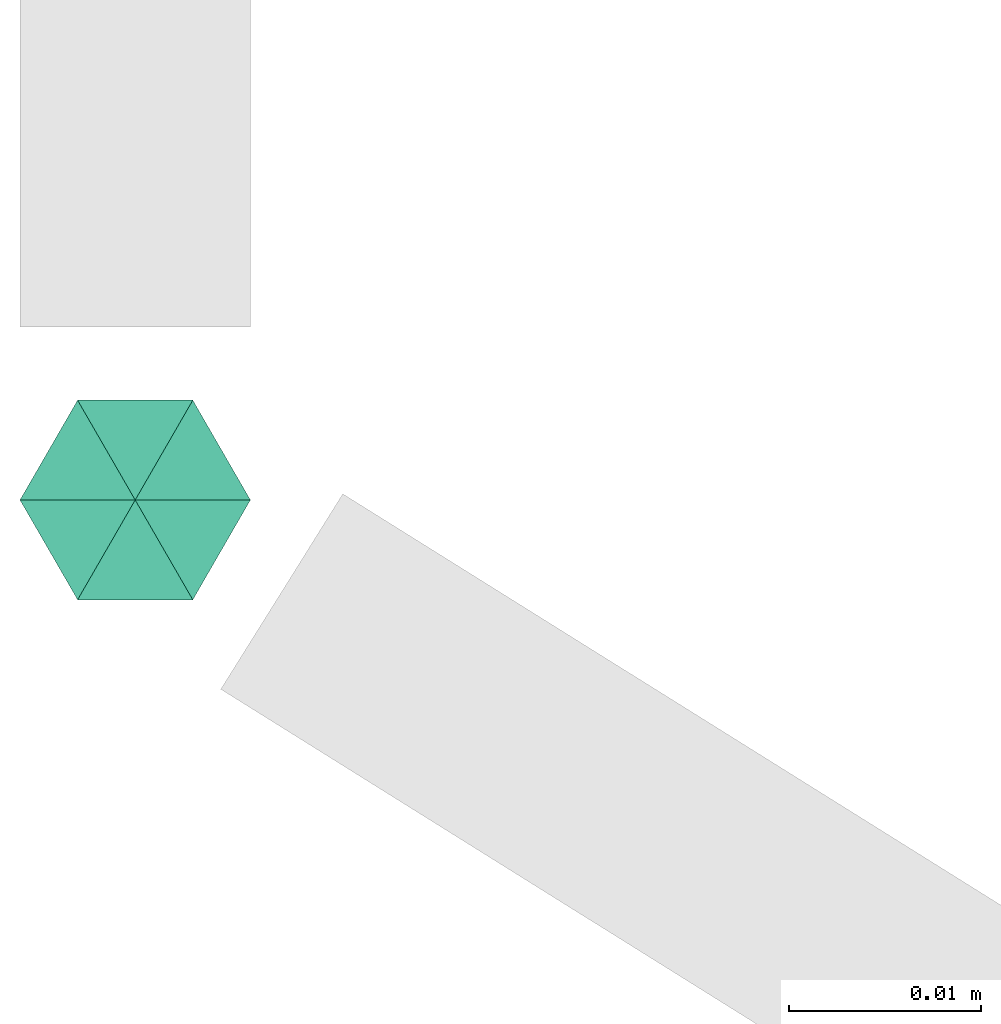
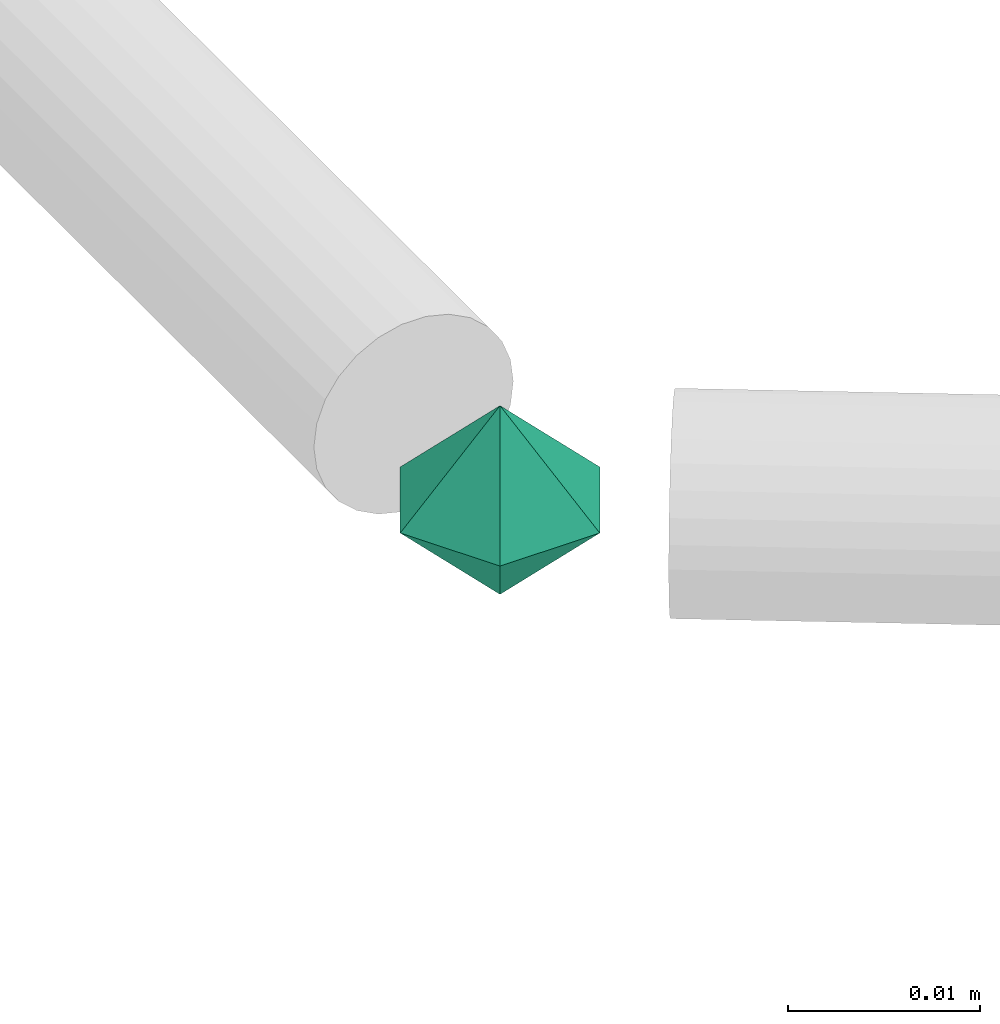
# One storey, part 64 of 65: 1 flow fitting.
"""IFC2X3 building model written with IfcOpenShell, lengths in millimetres."""

from ifc_helpers import new_model, entity, si_unit, converted_unit, derived_unit, direction, frame, origin, place, context, subcontext, project, spatial, faceted_brep, source, transform, mapped, material, material_list, type_object, type_shapes, element, save


model = new_model("IFC2X3")

# Units and contexts
model_context = context("Model", 3, precision=0.01, world=origin(), true_north=direction((6.12303176911189e-17, 1.0)))
body_context = subcontext(model_context, "Body", "Model", "MODEL_VIEW")
ifc_project = project(units=[si_unit("LENGTHUNIT", "METRE", prefix="MILLI"), si_unit("AREAUNIT", "SQUARE_METRE"), si_unit("VOLUMEUNIT", "CUBIC_METRE"), converted_unit("PLANEANGLEUNIT", "DEGREE", entity("IfcRatioMeasure", 0.0174532925199433), si_unit("PLANEANGLEUNIT", "RADIAN"), dimensions=[0, 0, 0, 0, 0, 0, 0]), si_unit("MASSUNIT", "GRAM", prefix="KILO"), derived_unit("MASSDENSITYUNIT", [(si_unit("MASSUNIT", "GRAM", prefix="KILO"), 1), (si_unit("LENGTHUNIT", "METRE"), -3)]), derived_unit("MOMENTOFINERTIAUNIT", [(si_unit("LENGTHUNIT", "METRE"), 4)]), si_unit("TIMEUNIT", "SECOND"), si_unit("FREQUENCYUNIT", "HERTZ"), si_unit("THERMODYNAMICTEMPERATUREUNIT", "DEGREE_CELSIUS"), derived_unit("THERMALTRANSMITTANCEUNIT", [(si_unit("MASSUNIT", "GRAM", prefix="KILO"), 1), (si_unit("THERMODYNAMICTEMPERATUREUNIT", "KELVIN"), -1), (si_unit("TIMEUNIT", "SECOND"), -3)]), derived_unit("VOLUMETRICFLOWRATEUNIT", [(si_unit("LENGTHUNIT", "METRE"), 3), (si_unit("TIMEUNIT", "SECOND"), -1)]), derived_unit("MASSFLOWRATEUNIT", [(si_unit("MASSUNIT", "GRAM", prefix="KILO"), 1), (si_unit("TIMEUNIT", "SECOND"), -1)]), derived_unit("ROTATIONALFREQUENCYUNIT", [(si_unit("TIMEUNIT", "SECOND"), -1)]), si_unit("ELECTRICCURRENTUNIT", "AMPERE"), si_unit("ELECTRICVOLTAGEUNIT", "VOLT"), si_unit("POWERUNIT", "WATT"), si_unit("FORCEUNIT", "NEWTON", prefix="KILO"), si_unit("ILLUMINANCEUNIT", "LUX"), si_unit("LUMINOUSFLUXUNIT", "LUMEN"), si_unit("LUMINOUSINTENSITYUNIT", "CANDELA"), derived_unit("USERDEFINED", [(si_unit("MASSUNIT", "GRAM", prefix="KILO"), -1), (si_unit("LENGTHUNIT", "METRE"), -2), (si_unit("TIMEUNIT", "SECOND"), 3), (si_unit("LUMINOUSFLUXUNIT", "LUMEN"), 1)]), derived_unit("LINEARVELOCITYUNIT", [(si_unit("LENGTHUNIT", "METRE"), 1), (si_unit("TIMEUNIT", "SECOND"), -1)]), si_unit("PRESSUREUNIT", "PASCAL"), derived_unit("USERDEFINED", [(si_unit("LENGTHUNIT", "METRE"), -2), (si_unit("MASSUNIT", "GRAM", prefix="KILO"), 1), (si_unit("TIMEUNIT", "SECOND"), -2)]), derived_unit("LINEARFORCEUNIT", [(si_unit("MASSUNIT", "GRAM", prefix="KILO"), 1), (si_unit("LENGTHUNIT", "METRE"), 1), (si_unit("TIMEUNIT", "SECOND"), -2), (si_unit("LENGTHUNIT", "METRE"), -1)]), derived_unit("PLANARFORCEUNIT", [(si_unit("MASSUNIT", "GRAM", prefix="KILO"), 1), (si_unit("LENGTHUNIT", "METRE"), 1), (si_unit("TIMEUNIT", "SECOND"), -2), (si_unit("LENGTHUNIT", "METRE"), -2)])], contexts=[model_context])

# Site, building, storey
site_placement = place(None, frame((0.0, -0.00077364408347762, 0.0)))
site = spatial("IfcSite", under=ifc_project, at=site_placement, CompositionType="ELEMENT")
building_placement = place(site_placement, origin())
building = spatial("IfcBuilding", under=site, at=building_placement, CompositionType="ELEMENT")
storey_placement = place(building_placement, frame((0.0, 0.0, 19800.0)))
storey = spatial("IfcBuildingStorey", under=building, at=storey_placement, CompositionType="ELEMENT", Elevation=19800.0)

# Flow fitting
ifc_material_1 = material()
ifc_material_2 = material()
ifc_material_list = material_list([ifc_material_2, ifc_material_1])
pipe_fitting_type = type_object("IfcPipeFittingType", PredefinedType="NOTDEFINED", material=ifc_material_list)
shared_shape = source(origin(), body_context, "Body", "Brep", [
    faceted_brep([(5.19615242271291, 3.0, 0.0), (1.81736279215797e-07, 1.95255430990304e-07, -6.0), (0.0, 6.0, 0.0), (5.19615242271289, -3.0, 0.0), (0.0, -6.0, 0.0), (-5.19615242270038, 3.0, 0.0), (-5.19615242270037, -3.0, 0.0), (-7.73803144365858e-08, 6.63990943561288e-08, 6.0)], [[[0, 1, 2]], [[1, 0, 3]], [[1, 3, 4]], [[5, 1, 6]], [[1, 4, 6]], [[2, 1, 5]], [[5, 7, 2]], [[7, 5, 6]], [[7, 6, 4]], [[0, 7, 3]], [[7, 4, 3]], [[2, 7, 0]]]),
])
type_shapes(pipe_fitting_type, [shared_shape])
flow_fitting_placement = place(storey_placement, frame((16330.0, 2925.00147018885, 3050.0), z_axis=(0.0, 0.0, 1.0), x_axis=(0.0, -1.0, 0.0)))
element("IfcFlowFitting", 1, at=flow_fitting_placement, inside=storey, type_object=pipe_fitting_type, material=ifc_material_1, context=body_context, shape_type="MappedRepresentation", body=[
    mapped(shared_shape, transform((0.0, 0.0, 0.0), scale=1.0)),
])

save(model, "model.ifc")
